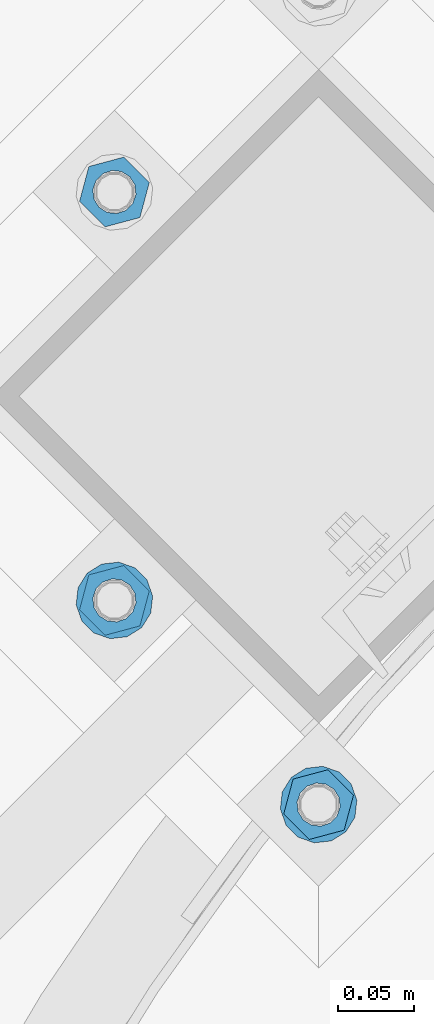
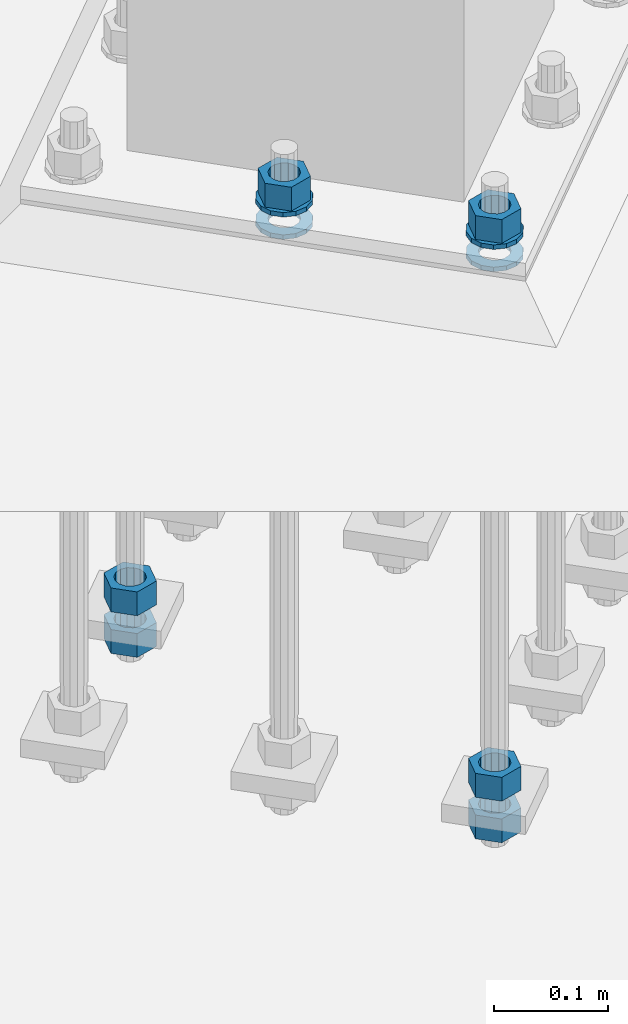
# One storey, part 872 of 1876: 10 columns, 1 element without a shape of its own.
"""IFC2X3 building model written with IfcOpenShell, lengths in millimetres."""

import ifcopenshell
import ifcopenshell.guid

model = None  # the IFC model being written
_history = None  # IfcOwnerHistory: only IFC2X3 demands one
_inside = {}  # id of a spatial element -> (the spatial element, [elements in it])
_under = {}  # id of a project, library or spatial element -> (it, [spatial elements below it])
_declared = {}  # id of a project -> (the project, [libraries it declares])
_typed = {}  # id of a type object -> (the type object, [elements of that type])
_made_of = {}  # id of a material, layer set ... -> (it, [elements and type objects made of it])


def new_model(schema):
    """Start an empty IFC model of exactly this schema.

    Asked for "IFC4X3", IfcOpenShell would pick the latest addendum, in which some entities
    have other attributes; the version numbers below select the first issue.
    IFC2X3 requires an IfcOwnerHistory on every rooted entity: one is made here for all.
    """
    global model, _history
    if schema == "IFC4X3":
        model = ifcopenshell.file(schema_version=(4, 3, 0, 0))
    else:
        model = ifcopenshell.file(schema=schema)
    _inside.clear()
    _under.clear()
    _declared.clear()
    _typed.clear()
    _made_of.clear()
    _history = None
    if model.schema == "IFC2X3":
        org = make("IfcOrganization", Name="unknown")
        user = make(
            "IfcPersonAndOrganization",
            ThePerson=make("IfcPerson", FamilyName="unknown"),
            TheOrganization=org,
        )
        app = make(
            "IfcApplication",
            ApplicationDeveloper=org,
            Version="unknown",
            ApplicationFullName="unknown",
            ApplicationIdentifier="unknown",
        )
        _history = make(
            "IfcOwnerHistory",
            OwningUser=user,
            OwningApplication=app,
            ChangeAction="ADDED",
            CreationDate=0,
        )
    return model


def make(cls, **values):
    """One entity of the class cls with the attributes given. An attribute that is None is left unset."""
    return model.create_entity(
        cls, **{name: value for name, value in values.items() if value is not None}
    )


def rooted(cls, **values):
    """An entity with a GlobalId (a new one), such as an element, a storey or a relation."""
    return make(cls, GlobalId=ifcopenshell.guid.new(), OwnerHistory=_history, **values)


def si_unit(unit_type, name, prefix=None):
    """IfcSIUnit, for example si_unit("LENGTHUNIT", "METRE", prefix="MILLI")."""
    return make("IfcSIUnit", UnitType=unit_type, Prefix=prefix, Name=name)


def assignment(units):
    """IfcUnitAssignment: the units of a project."""
    return None if units is None else make("IfcUnitAssignment", Units=units)


def point(xyz):
    """IfcCartesianPoint."""
    return None if xyz is None else make("IfcCartesianPoint", Coordinates=xyz)


def direction(xyz):
    """IfcDirection."""
    return None if xyz is None else make("IfcDirection", DirectionRatios=xyz)


def frame(location, z_axis=None, x_axis=None):
    """IfcAxis2Placement3D, a coordinate frame: its origin and axes. An axis left out is left unset."""
    return make(
        "IfcAxis2Placement3D",
        Location=point(location),
        Axis=direction(z_axis),
        RefDirection=direction(x_axis),
    )


def origin_with_axes():
    """The frame at (0, 0, 0) with the z axis (0, 0, 1) and the x axis (1, 0, 0) written out."""
    return frame((0.0, 0.0, 0.0), z_axis=(0.0, 0.0, 1.0), x_axis=(1.0, 0.0, 0.0))


def place(relative_to, where):
    """IfcLocalPlacement: puts the frame where relative to a parent placement (None: the world)."""
    return make(
        "IfcLocalPlacement", PlacementRelTo=relative_to, RelativePlacement=where
    )


def context(
    kind, dimensions, precision=None, world=None, true_north=None, identifier=None
):
    """IfcGeometricRepresentationContext, for example the 3D "Model" context."""
    return make(
        "IfcGeometricRepresentationContext",
        ContextIdentifier=identifier,
        ContextType=kind,
        CoordinateSpaceDimension=dimensions,
        Precision=precision,
        WorldCoordinateSystem=world,
        TrueNorth=true_north,
    )


def subcontext(parent, identifier, kind, view, scale=None):
    """IfcGeometricRepresentationSubContext, for example "Body" below "Model"."""
    return make(
        "IfcGeometricRepresentationSubContext",
        ContextIdentifier=identifier,
        ContextType=kind,
        ParentContext=parent,
        TargetScale=scale,
        TargetView=view,
    )


def project(units=None, contexts=None):
    """IfcProject with its units and contexts."""
    return rooted(
        "IfcProject",
        Name="project",
        RepresentationContexts=contexts,
        UnitsInContext=assignment(units),
    )


def spatial(cls, under=None, at=None, **own):
    """A site, building, storey or space (cls), placed at a placement, below another one or the project."""
    s = rooted(cls, ObjectPlacement=at, **own)
    if under is not None:
        _under.setdefault(under.id(), (under, []))[1].append(s)
    return s


def faces_of(points, faces, orient=None, outer=None):
    """IfcFace entities. A face is a list of loops; a loop is a list of indices into points, from 0.

    orient and outer hold one flag for each loop. By default every Orientation is true, the
    first loop of a face is its IfcFaceOuterBound and the others are IfcFaceBound.
    """
    made = []
    for i, loops in enumerate(faces):
        bounds = []
        for j, loop in enumerate(loops):
            is_outer = j == 0 if outer is None else outer[i][j]
            bounds.append(
                make(
                    "IfcFaceOuterBound" if is_outer else "IfcFaceBound",
                    Bound=make("IfcPolyLoop", Polygon=[points[k] for k in loop]),
                    Orientation=True if orient is None else orient[i][j],
                )
            )
        made.append(make("IfcFace", Bounds=bounds))
    return made


def faceted_brep(points, faces, orient=None, outer=None, voids=None):
    """IfcFacetedBrep: a solid bounded by flat faces; with voids (closed shells), ...WithVoids."""
    shared = [point(p) for p in points]
    hull = make("IfcClosedShell", CfsFaces=faces_of(shared, faces, orient, outer))
    if voids is None:
        return make("IfcFacetedBrep", Outer=hull)
    return make(
        "IfcFacetedBrepWithVoids",
        Outer=hull,
        Voids=[
            make(cls, CfsFaces=faces_of(shared, fs, o, b)) for cls, fs, o, b in voids
        ],
    )


def shape(context_of_items, identifier, shape_type, items):
    """IfcShapeRepresentation: the items that make up one representation, for example the "Body"."""
    return make(
        "IfcShapeRepresentation",
        ContextOfItems=context_of_items,
        RepresentationIdentifier=identifier,
        RepresentationType=shape_type,
        Items=items,
    )


def material(Name=None, Category=None):
    """IfcMaterial."""
    return make("IfcMaterial", Name=Name, Category=Category)


def made_of(thing, what):
    """Note that an element or type object is made of a material, layer set ...; save() writes the relation."""
    if what is not None:
        _made_of.setdefault(what.id(), (what, []))[1].append(thing)
    return thing


def type_object(cls, material=None, **own):
    """A type object (cls), such as IfcWallType, which elements share."""
    return made_of(rooted(cls, **own), material)


def element(
    cls,
    number,
    at=None,
    inside=None,
    cuts=None,
    type_object=None,
    material=None,
    context=None,
    identifier="Body",
    shape_type=None,
    held_by="IfcProductDefinitionShape",
    body=None,
    shapes=None,
    **own,
):
    """One element of the class cls, such as IfcWall. Its Tag is "e" and its number.

    at: its placement. inside: the storey or other place that contains it. cuts: it is an
    opening in that element (IfcRelVoidsElement). A single representation is given by context,
    identifier, shape_type and body (its items); several are given by shapes. held_by: the class
    of the entity that holds the representations. save() writes the other relations.
    """
    e = rooted(cls, Tag="e%d" % number, ObjectPlacement=at, **own)
    if body is not None:
        shapes = [shape(context, identifier, shape_type, body)]
    if shapes is not None:
        e.Representation = make(held_by, Representations=shapes)
    if inside is not None:
        _inside.setdefault(inside.id(), (inside, []))[1].append(e)
    if cuts is not None:
        rooted(
            "IfcRelVoidsElement", RelatingBuildingElement=cuts, RelatedOpeningElement=e
        )
    if type_object is not None:
        _typed.setdefault(type_object.id(), (type_object, []))[1].append(e)
    return made_of(e, material)


def aggregate(whole, parts):
    """IfcRelAggregates: a whole, such as a stair, and the parts it consists of."""
    return rooted("IfcRelAggregates", RelatingObject=whole, RelatedObjects=parts)


def save(model, path):
    """Write the relations noted so far, then the file.

    IfcRelAggregates (storeys below a building ...), IfcRelContainedInSpatialStructure (elements
    in a storey), IfcRelDefinesByType, IfcRelAssociatesMaterial and IfcRelDeclares: one each for
    every whole, place, type object, material and project.
    """
    for whole, parts in _under.values():
        aggregate(whole, parts)
    for where, things in _inside.values():
        rooted(
            "IfcRelContainedInSpatialStructure",
            RelatedElements=things,
            RelatingStructure=where,
        )
    for kind, things in _typed.values():
        rooted("IfcRelDefinesByType", RelatedObjects=things, RelatingType=kind)
    for what, things in _made_of.values():
        rooted("IfcRelAssociatesMaterial", RelatedObjects=things, RelatingMaterial=what)
    for by, libraries in _declared.values():
        rooted("IfcRelDeclares", RelatingContext=by, RelatedDefinitions=libraries)
    model.write(path)


model = new_model("IFC2X3")

# Units and contexts
model_context = context("Model", 3, precision=1e-05, world=origin_with_axes())
body_context = subcontext(model_context, "Body", "Model", "MODEL_VIEW")
ifc_project = project(units=[si_unit("LENGTHUNIT", "METRE", prefix="MILLI"), si_unit("AREAUNIT", "SQUARE_METRE"), si_unit("VOLUMEUNIT", "CUBIC_METRE"), si_unit("MASSUNIT", "GRAM", prefix="KILO"), si_unit("TIMEUNIT", "SECOND"), si_unit("PLANEANGLEUNIT", "RADIAN"), si_unit("SOLIDANGLEUNIT", "STERADIAN"), si_unit("THERMODYNAMICTEMPERATUREUNIT", "DEGREE_CELSIUS"), si_unit("LUMINOUSINTENSITYUNIT", "LUMEN")], contexts=[model_context])

# Site, building, storey
site_placement = place(None, origin_with_axes())
site = spatial("IfcSite", under=ifc_project, at=site_placement, CompositionType="ELEMENT")
building_placement = place(site_placement, origin_with_axes())
building = spatial("IfcBuilding", under=site, at=building_placement, Name="Undefined", CompositionType="ELEMENT")
storey_placement = place(building_placement, origin_with_axes())
storey = spatial("IfcBuildingStorey", under=building, at=storey_placement, Name="Undefined", CompositionType="ELEMENT", Elevation=0.0)

# Assembly, columns
assembly_placement = place(storey_placement, origin_with_axes())
assembly = element("IfcElementAssembly", 1, at=assembly_placement, inside=storey, Name="TEMPLATE", AssemblyPlace="NOTDEFINED", PredefinedType="RIGID_FRAME")
ifc_material_1 = material(Name="STEEL/A563")
column_type_1 = type_object("IfcColumnType", Name="1_HEAVY_HEX_NUT", PredefinedType="NOTDEFINED")
column_1_placement = place(assembly_placement, frame((3648.30903754913, -12055.5665371028, -508.0), z_axis=(-0.707106781186547, -0.707106781186548, 0.0), x_axis=(0.0, 0.0, -1.0)))
column_1 = element("IfcColumn", 2, at=column_1_placement, type_object=column_type_1, material=ifc_material_1, Name="NUT", ObjectType="1_HEAVY_HEX_NUT", context=body_context, shape_type="Brep", body=[
    faceted_brep([(0.0, -23.8099994659442, 9.09494701772928e-13), (0.0, -11.9099998474121, -20.6200008392352), (25.4, -11.9099998474157, -20.6200008392361), (25.4, -23.8099994659478, 0.0), (0.0, 11.9099998474157, -20.620000839237), (25.4, 11.9099998474121, -20.620000839237), (0.0, 23.8099994659478, 9.09494701772928e-13), (25.4, 23.8099994659442, 0.0), (0.0, 11.9099998474157, 20.620000839237), (25.4, 11.9099998474121, 20.620000839237), (0.0, -11.9099998474121, 20.6200008392389), (25.4, -11.9099998474157, 20.6200008392379), (0.0, 1.81898940354586e-12, 14.2899999618567), (0.0, 6.20019861543915, 12.8748450879584), (25.4, 6.20019861543733, 12.8748450879593), (25.4, 0.0, 14.2899999618558), (0.0, 11.1723718546473, 8.90966924477925), (25.4, 11.1723718546436, 8.90966924477925), (0.0, 13.9317198278914, 3.17982413774916), (25.4, 13.9317198278877, 3.17982413775007), (0.0, 13.9317198278914, -3.17982413774644), (25.4, 13.9317198278895, -3.17982413774735), (0.0, 11.1723718546473, -8.90966924477834), (25.4, 11.1723718546455, -8.90966924477925), (0.0, 6.20019861544279, -12.8748450879575), (25.4, 6.20019861543915, -12.8748450879584), (0.0, 3.63797880709171e-12, -14.2899999618548), (25.4, -3.63797880709171e-12, -14.2899999618548), (0.0, -6.20019861543733, -12.8748450879566), (25.4, -6.20019861544097, -12.8748450879584), (0.0, -11.1723718546455, -8.90966924477743), (25.4, -11.1723718546473, -8.90966924477834), (0.0, -13.9317198278877, -3.17982413774735), (25.4, -13.9317198278914, -3.17982413774826), (0.0, -13.9317198278895, 3.17982413774735), (25.4, -13.9317198278914, 3.17982413774826), (0.0, -11.1723718546455, 8.90966924477925), (25.4, -11.1723718546473, 8.90966924478016), (0.0, -6.20019861543915, 12.8748450879593), (25.4, -6.20019861544279, 12.8748450879593)], [[[0, 1, 2, 3]], [[1, 4, 5, 2]], [[4, 6, 7, 5]], [[6, 8, 9, 7]], [[8, 10, 11, 9]], [[10, 0, 3, 11]], [[12, 13, 14, 15]], [[13, 16, 17, 14]], [[16, 18, 19, 17]], [[18, 20, 21, 19]], [[20, 22, 23, 21]], [[22, 24, 25, 23]], [[24, 26, 27, 25]], [[26, 28, 29, 27]], [[28, 30, 31, 29]], [[30, 32, 33, 31]], [[32, 34, 35, 33]], [[34, 36, 37, 35]], [[36, 38, 39, 37]], [[38, 12, 15, 39]], [[5, 7, 9, 11, 3, 2], [17, 19, 21, 23, 25, 27, 29, 31, 33, 35, 37, 39, 15, 14]], [[10, 8, 6, 4, 1, 0], [38, 36, 34, 32, 30, 28, 26, 24, 22, 20, 18, 16, 13, 12]]]),
])
column_2_placement = place(assembly_placement, frame((3648.30903754913, -12055.5665371028, -552.45), z_axis=(-0.707106781186547, -0.707106781186548, 0.0), x_axis=(0.0, 0.0, -1.0)))
column_2 = element("IfcColumn", 3, at=column_2_placement, type_object=column_type_1, material=ifc_material_1, Name="NUT", ObjectType="1_HEAVY_HEX_NUT", context=body_context, shape_type="Brep", body=[
    faceted_brep([(0.0, -23.8099994659442, 9.09494701772928e-13), (0.0, -11.9099998474121, -20.6200008392352), (25.4, -11.9099998474157, -20.6200008392361), (25.4, -23.8099994659478, 0.0), (0.0, 11.9099998474157, -20.620000839237), (25.4, 11.9099998474121, -20.620000839237), (0.0, 23.8099994659478, 9.09494701772928e-13), (25.4, 23.8099994659442, 0.0), (0.0, 11.9099998474157, 20.620000839237), (25.4, 11.9099998474121, 20.620000839237), (0.0, -11.9099998474121, 20.6200008392389), (25.4, -11.9099998474157, 20.6200008392379), (0.0, 1.81898940354586e-12, 14.2899999618567), (0.0, 6.20019861543915, 12.8748450879584), (25.4, 6.20019861543733, 12.8748450879593), (25.4, 0.0, 14.2899999618558), (0.0, 11.1723718546473, 8.90966924477925), (25.4, 11.1723718546436, 8.90966924477925), (0.0, 13.9317198278914, 3.17982413774916), (25.4, 13.9317198278877, 3.17982413775007), (0.0, 13.9317198278914, -3.17982413774644), (25.4, 13.9317198278895, -3.17982413774735), (0.0, 11.1723718546473, -8.90966924477834), (25.4, 11.1723718546455, -8.90966924477925), (0.0, 6.20019861544279, -12.8748450879575), (25.4, 6.20019861543915, -12.8748450879584), (0.0, 3.63797880709171e-12, -14.2899999618548), (25.4, -3.63797880709171e-12, -14.2899999618548), (0.0, -6.20019861543733, -12.8748450879566), (25.4, -6.20019861544097, -12.8748450879584), (0.0, -11.1723718546455, -8.90966924477743), (25.4, -11.1723718546473, -8.90966924477834), (0.0, -13.9317198278877, -3.17982413774735), (25.4, -13.9317198278914, -3.17982413774826), (0.0, -13.9317198278895, 3.17982413774735), (25.4, -13.9317198278914, 3.17982413774826), (0.0, -11.1723718546455, 8.90966924477925), (25.4, -11.1723718546473, 8.90966924478016), (0.0, -6.20019861543915, 12.8748450879593), (25.4, -6.20019861544279, 12.8748450879593)], [[[0, 1, 2, 3]], [[1, 4, 5, 2]], [[4, 6, 7, 5]], [[6, 8, 9, 7]], [[8, 10, 11, 9]], [[10, 0, 3, 11]], [[12, 13, 14, 15]], [[13, 16, 17, 14]], [[16, 18, 19, 17]], [[18, 20, 21, 19]], [[20, 22, 23, 21]], [[22, 24, 25, 23]], [[24, 26, 27, 25]], [[26, 28, 29, 27]], [[28, 30, 31, 29]], [[30, 32, 33, 31]], [[32, 34, 35, 33]], [[34, 36, 37, 35]], [[36, 38, 39, 37]], [[38, 12, 15, 39]], [[5, 7, 9, 11, 3, 2], [17, 19, 21, 23, 25, 27, 29, 31, 33, 35, 37, 39, 15, 14]], [[10, 8, 6, 4, 1, 0], [38, 36, 34, 32, 30, 28, 26, 24, 22, 20, 18, 16, 13, 12]]]),
])
column_3_placement = place(assembly_placement, frame((3783.01287936528, -12459.6780625513, 87.3125), z_axis=(0.707106781186548, 0.707106781186547, 0.0), x_axis=(0.0, 0.0, -1.0)))
column_3 = element("IfcColumn", 4, at=column_3_placement, type_object=column_type_1, material=ifc_material_1, Name="NUT", ObjectType="1_HEAVY_HEX_NUT", context=body_context, shape_type="Brep", body=[
    faceted_brep([(0.0, -23.8099994659442, 9.09494701772928e-13), (0.0, -11.9099998474121, -20.6200008392352), (25.4, -11.9099998474157, -20.6200008392361), (25.4, -23.8099994659478, 0.0), (0.0, 11.9099998474157, -20.620000839237), (25.4, 11.9099998474121, -20.620000839237), (0.0, 23.8099994659478, 9.09494701772928e-13), (25.4, 23.8099994659442, 0.0), (0.0, 11.9099998474157, 20.620000839237), (25.4, 11.9099998474121, 20.620000839237), (0.0, -11.9099998474121, 20.6200008392389), (25.4, -11.9099998474157, 20.6200008392379), (0.0, 1.81898940354586e-12, 14.2899999618567), (0.0, 6.20019861543915, 12.8748450879584), (25.4, 6.20019861543733, 12.8748450879593), (25.4, 0.0, 14.2899999618558), (0.0, 11.1723718546473, 8.90966924477925), (25.4, 11.1723718546436, 8.90966924477925), (0.0, 13.9317198278914, 3.17982413774916), (25.4, 13.9317198278877, 3.17982413775007), (0.0, 13.9317198278914, -3.17982413774644), (25.4, 13.9317198278895, -3.17982413774735), (0.0, 11.1723718546473, -8.90966924477834), (25.4, 11.1723718546455, -8.90966924477925), (0.0, 6.20019861544279, -12.8748450879575), (25.4, 6.20019861543915, -12.8748450879584), (0.0, 3.63797880709171e-12, -14.2899999618548), (25.4, -3.63797880709171e-12, -14.2899999618548), (0.0, -6.20019861543733, -12.8748450879566), (25.4, -6.20019861544097, -12.8748450879584), (0.0, -11.1723718546455, -8.90966924477743), (25.4, -11.1723718546473, -8.90966924477834), (0.0, -13.9317198278877, -3.17982413774735), (25.4, -13.9317198278914, -3.17982413774826), (0.0, -13.9317198278895, 3.17982413774735), (25.4, -13.9317198278914, 3.17982413774826), (0.0, -11.1723718546455, 8.90966924477925), (25.4, -11.1723718546473, 8.90966924478016), (0.0, -6.20019861543915, 12.8748450879593), (25.4, -6.20019861544279, 12.8748450879593)], [[[0, 1, 2, 3]], [[1, 4, 5, 2]], [[4, 6, 7, 5]], [[6, 8, 9, 7]], [[8, 10, 11, 9]], [[10, 0, 3, 11]], [[12, 13, 14, 15]], [[13, 16, 17, 14]], [[16, 18, 19, 17]], [[18, 20, 21, 19]], [[20, 22, 23, 21]], [[22, 24, 25, 23]], [[24, 26, 27, 25]], [[26, 28, 29, 27]], [[28, 30, 31, 29]], [[30, 32, 33, 31]], [[32, 34, 35, 33]], [[34, 36, 37, 35]], [[36, 38, 39, 37]], [[38, 12, 15, 39]], [[5, 7, 9, 11, 3, 2], [17, 19, 21, 23, 25, 27, 29, 31, 33, 35, 37, 39, 15, 14]], [[10, 8, 6, 4, 1, 0], [38, 36, 34, 32, 30, 28, 26, 24, 22, 20, 18, 16, 13, 12]]]),
])
column_4_placement = place(assembly_placement, frame((3783.01287936528, -12459.6780625513, -508.0), z_axis=(0.707106781186548, 0.707106781186547, 0.0), x_axis=(0.0, 0.0, -1.0)))
column_4 = element("IfcColumn", 5, at=column_4_placement, type_object=column_type_1, material=ifc_material_1, Name="NUT", ObjectType="1_HEAVY_HEX_NUT", context=body_context, shape_type="Brep", body=[
    faceted_brep([(0.0, -23.8099994659442, 9.09494701772928e-13), (0.0, -11.9099998474121, -20.6200008392352), (25.4, -11.9099998474157, -20.6200008392361), (25.4, -23.8099994659478, 0.0), (0.0, 11.9099998474157, -20.620000839237), (25.4, 11.9099998474121, -20.620000839237), (0.0, 23.8099994659478, 9.09494701772928e-13), (25.4, 23.8099994659442, 0.0), (0.0, 11.9099998474157, 20.620000839237), (25.4, 11.9099998474121, 20.620000839237), (0.0, -11.9099998474121, 20.6200008392389), (25.4, -11.9099998474157, 20.6200008392379), (0.0, 1.81898940354586e-12, 14.2899999618567), (0.0, 6.20019861543915, 12.8748450879584), (25.4, 6.20019861543733, 12.8748450879593), (25.4, 0.0, 14.2899999618558), (0.0, 11.1723718546473, 8.90966924477925), (25.4, 11.1723718546436, 8.90966924477925), (0.0, 13.9317198278914, 3.17982413774916), (25.4, 13.9317198278877, 3.17982413775007), (0.0, 13.9317198278914, -3.17982413774644), (25.4, 13.9317198278895, -3.17982413774735), (0.0, 11.1723718546473, -8.90966924477834), (25.4, 11.1723718546455, -8.90966924477925), (0.0, 6.20019861544279, -12.8748450879575), (25.4, 6.20019861543915, -12.8748450879584), (0.0, 3.63797880709171e-12, -14.2899999618548), (25.4, -3.63797880709171e-12, -14.2899999618548), (0.0, -6.20019861543733, -12.8748450879566), (25.4, -6.20019861544097, -12.8748450879584), (0.0, -11.1723718546455, -8.90966924477743), (25.4, -11.1723718546473, -8.90966924477834), (0.0, -13.9317198278877, -3.17982413774735), (25.4, -13.9317198278914, -3.17982413774826), (0.0, -13.9317198278895, 3.17982413774735), (25.4, -13.9317198278914, 3.17982413774826), (0.0, -11.1723718546455, 8.90966924477925), (25.4, -11.1723718546473, 8.90966924478016), (0.0, -6.20019861543915, 12.8748450879593), (25.4, -6.20019861544279, 12.8748450879593)], [[[0, 1, 2, 3]], [[1, 4, 5, 2]], [[4, 6, 7, 5]], [[6, 8, 9, 7]], [[8, 10, 11, 9]], [[10, 0, 3, 11]], [[12, 13, 14, 15]], [[13, 16, 17, 14]], [[16, 18, 19, 17]], [[18, 20, 21, 19]], [[20, 22, 23, 21]], [[22, 24, 25, 23]], [[24, 26, 27, 25]], [[26, 28, 29, 27]], [[28, 30, 31, 29]], [[30, 32, 33, 31]], [[32, 34, 35, 33]], [[34, 36, 37, 35]], [[36, 38, 39, 37]], [[38, 12, 15, 39]], [[5, 7, 9, 11, 3, 2], [17, 19, 21, 23, 25, 27, 29, 31, 33, 35, 37, 39, 15, 14]], [[10, 8, 6, 4, 1, 0], [38, 36, 34, 32, 30, 28, 26, 24, 22, 20, 18, 16, 13, 12]]]),
])
column_5_placement = place(assembly_placement, frame((3783.01287936528, -12459.6780625513, -552.45), z_axis=(0.707106781186548, 0.707106781186547, 0.0), x_axis=(0.0, 0.0, -1.0)))
column_5 = element("IfcColumn", 6, at=column_5_placement, type_object=column_type_1, material=ifc_material_1, Name="NUT", ObjectType="1_HEAVY_HEX_NUT", context=body_context, shape_type="Brep", body=[
    faceted_brep([(0.0, -23.8099994659442, 9.09494701772928e-13), (0.0, -11.9099998474121, -20.6200008392352), (25.4, -11.9099998474157, -20.6200008392361), (25.4, -23.8099994659478, 0.0), (0.0, 11.9099998474157, -20.620000839237), (25.4, 11.9099998474121, -20.620000839237), (0.0, 23.8099994659478, 9.09494701772928e-13), (25.4, 23.8099994659442, 0.0), (0.0, 11.9099998474157, 20.620000839237), (25.4, 11.9099998474121, 20.620000839237), (0.0, -11.9099998474121, 20.6200008392389), (25.4, -11.9099998474157, 20.6200008392379), (0.0, 1.81898940354586e-12, 14.2899999618567), (0.0, 6.20019861543915, 12.8748450879584), (25.4, 6.20019861543733, 12.8748450879593), (25.4, 0.0, 14.2899999618558), (0.0, 11.1723718546473, 8.90966924477925), (25.4, 11.1723718546436, 8.90966924477925), (0.0, 13.9317198278914, 3.17982413774916), (25.4, 13.9317198278877, 3.17982413775007), (0.0, 13.9317198278914, -3.17982413774644), (25.4, 13.9317198278895, -3.17982413774735), (0.0, 11.1723718546473, -8.90966924477834), (25.4, 11.1723718546455, -8.90966924477925), (0.0, 6.20019861544279, -12.8748450879575), (25.4, 6.20019861543915, -12.8748450879584), (0.0, 3.63797880709171e-12, -14.2899999618548), (25.4, -3.63797880709171e-12, -14.2899999618548), (0.0, -6.20019861543733, -12.8748450879566), (25.4, -6.20019861544097, -12.8748450879584), (0.0, -11.1723718546455, -8.90966924477743), (25.4, -11.1723718546473, -8.90966924477834), (0.0, -13.9317198278877, -3.17982413774735), (25.4, -13.9317198278914, -3.17982413774826), (0.0, -13.9317198278895, 3.17982413774735), (25.4, -13.9317198278914, 3.17982413774826), (0.0, -11.1723718546455, 8.90966924477925), (25.4, -11.1723718546473, 8.90966924478016), (0.0, -6.20019861543915, 12.8748450879593), (25.4, -6.20019861544279, 12.8748450879593)], [[[0, 1, 2, 3]], [[1, 4, 5, 2]], [[4, 6, 7, 5]], [[6, 8, 9, 7]], [[8, 10, 11, 9]], [[10, 0, 3, 11]], [[12, 13, 14, 15]], [[13, 16, 17, 14]], [[16, 18, 19, 17]], [[18, 20, 21, 19]], [[20, 22, 23, 21]], [[22, 24, 25, 23]], [[24, 26, 27, 25]], [[26, 28, 29, 27]], [[28, 30, 31, 29]], [[30, 32, 33, 31]], [[32, 34, 35, 33]], [[34, 36, 37, 35]], [[36, 38, 39, 37]], [[38, 12, 15, 39]], [[5, 7, 9, 11, 3, 2], [17, 19, 21, 23, 25, 27, 29, 31, 33, 35, 37, 39, 15, 14]], [[10, 8, 6, 4, 1, 0], [38, 36, 34, 32, 30, 28, 26, 24, 22, 20, 18, 16, 13, 12]]]),
])
column_6_placement = place(assembly_placement, frame((3648.30903754913, -12324.9742207351, 87.3125), z_axis=(0.707106781186548, 0.707106781186547, 0.0), x_axis=(0.0, 0.0, -1.0)))
column_6 = element("IfcColumn", 7, at=column_6_placement, type_object=column_type_1, material=ifc_material_1, Name="NUT", ObjectType="1_HEAVY_HEX_NUT", context=body_context, shape_type="Brep", body=[
    faceted_brep([(0.0, -23.8099994659442, 9.09494701772928e-13), (0.0, -11.9099998474121, -20.6200008392352), (25.4, -11.9099998474157, -20.6200008392361), (25.4, -23.8099994659478, 0.0), (0.0, 11.9099998474157, -20.620000839237), (25.4, 11.9099998474121, -20.620000839237), (0.0, 23.8099994659478, 9.09494701772928e-13), (25.4, 23.8099994659442, 0.0), (0.0, 11.9099998474157, 20.620000839237), (25.4, 11.9099998474121, 20.620000839237), (0.0, -11.9099998474121, 20.6200008392389), (25.4, -11.9099998474157, 20.6200008392379), (0.0, 1.81898940354586e-12, 14.2899999618567), (0.0, 6.20019861543915, 12.8748450879584), (25.4, 6.20019861543733, 12.8748450879593), (25.4, 0.0, 14.2899999618558), (0.0, 11.1723718546473, 8.90966924477925), (25.4, 11.1723718546436, 8.90966924477925), (0.0, 13.9317198278914, 3.17982413774916), (25.4, 13.9317198278877, 3.17982413775007), (0.0, 13.9317198278914, -3.17982413774644), (25.4, 13.9317198278895, -3.17982413774735), (0.0, 11.1723718546473, -8.90966924477834), (25.4, 11.1723718546455, -8.90966924477925), (0.0, 6.20019861544279, -12.8748450879575), (25.4, 6.20019861543915, -12.8748450879584), (0.0, 3.63797880709171e-12, -14.2899999618548), (25.4, -3.63797880709171e-12, -14.2899999618548), (0.0, -6.20019861543733, -12.8748450879566), (25.4, -6.20019861544097, -12.8748450879584), (0.0, -11.1723718546455, -8.90966924477743), (25.4, -11.1723718546473, -8.90966924477834), (0.0, -13.9317198278877, -3.17982413774735), (25.4, -13.9317198278914, -3.17982413774826), (0.0, -13.9317198278895, 3.17982413774735), (25.4, -13.9317198278914, 3.17982413774826), (0.0, -11.1723718546455, 8.90966924477925), (25.4, -11.1723718546473, 8.90966924478016), (0.0, -6.20019861543915, 12.8748450879593), (25.4, -6.20019861544279, 12.8748450879593)], [[[0, 1, 2, 3]], [[1, 4, 5, 2]], [[4, 6, 7, 5]], [[6, 8, 9, 7]], [[8, 10, 11, 9]], [[10, 0, 3, 11]], [[12, 13, 14, 15]], [[13, 16, 17, 14]], [[16, 18, 19, 17]], [[18, 20, 21, 19]], [[20, 22, 23, 21]], [[22, 24, 25, 23]], [[24, 26, 27, 25]], [[26, 28, 29, 27]], [[28, 30, 31, 29]], [[30, 32, 33, 31]], [[32, 34, 35, 33]], [[34, 36, 37, 35]], [[36, 38, 39, 37]], [[38, 12, 15, 39]], [[5, 7, 9, 11, 3, 2], [17, 19, 21, 23, 25, 27, 29, 31, 33, 35, 37, 39, 15, 14]], [[10, 8, 6, 4, 1, 0], [38, 36, 34, 32, 30, 28, 26, 24, 22, 20, 18, 16, 13, 12]]]),
])
ifc_material_2 = material(Name="STEEL/F436")
column_type_2 = type_object("IfcColumnType", Name="1_WASHER", PredefinedType="NOTDEFINED")
column_7_placement = place(assembly_placement, frame((3783.01287936528, -12459.6780625513, 38.1), z_axis=(0.707106781186548, 0.707106781186547, 0.0), x_axis=(0.0, 0.0, -1.0)))
column_7 = element("IfcColumn", 8, at=column_7_placement, type_object=column_type_2, material=ifc_material_2, Name="WASHER", ObjectType="1_WASHER", context=body_context, shape_type="Brep", body=[
    faceted_brep([(0.0, -25.3999996185375, 0.0), (0.0, -22.8846089010331, -11.0206468080742), (4.7625, -22.8846089010331, -11.0206468080742), (4.7625, -25.3999996185375, 0.0), (0.0, -15.8366407293743, -19.8585193564477), (4.7625, -15.8366407293743, -19.8585193564477), (0.0, -5.65203163760816, -24.7631685975166), (4.7625, -5.65203163760816, -24.7631685975166), (0.0, 5.65203163760452, -24.7631685975166), (4.7625, 5.65203163760452, -24.7631685975166), (0.0, 15.8366407293706, -19.858519356445), (4.7625, 15.8366407293706, -19.858519356445), (0.0, 22.8846089010331, -11.0206468080733), (4.7625, 22.8846089010331, -11.0206468080733), (0.0, 25.3999996185339, 9.09494701772928e-13), (4.7625, 25.3999996185339, 9.09494701772928e-13), (0.0, 22.8846089010331, 11.0206468080751), (4.7625, 22.8846089010331, 11.0206468080751), (0.0, 15.8366407293706, 19.8585193564486), (4.7625, 15.8366407293706, 19.8585193564486), (0.0, 5.65203163760452, 24.7631685975175), (4.7625, 5.65203163760452, 24.7631685975175), (0.0, -5.65203163760816, 24.7631685975175), (4.7625, -5.65203163760816, 24.7631685975175), (0.0, -15.8366407293724, 19.8585193564459), (4.7625, -15.8366407293724, 19.8585193564459), (0.0, -22.8846089010367, 11.0206468080751), (4.7625, -22.8846089010367, 11.0206468080751), (0.0, 1.81898940354586e-12, 14.2899999618567), (0.0, 6.20019861543915, 12.8748450879584), (4.7625, 6.20019861543733, 12.8748450879593), (4.7625, 0.0, 14.2899999618558), (0.0, 11.1723718546473, 8.90966924477925), (4.7625, 11.1723718546436, 8.90966924477925), (0.0, 13.9317198278914, 3.17982413774916), (4.7625, 13.9317198278877, 3.17982413775007), (0.0, 13.9317198278914, -3.17982413774644), (4.7625, 13.9317198278895, -3.17982413774735), (0.0, 11.1723718546473, -8.90966924477834), (4.7625, 11.1723718546455, -8.90966924477925), (0.0, 6.20019861544279, -12.8748450879575), (4.7625, 6.20019861543915, -12.8748450879584), (0.0, 3.63797880709171e-12, -14.2899999618548), (4.7625, -3.63797880709171e-12, -14.2899999618548), (0.0, -6.20019861543733, -12.8748450879566), (4.7625, -6.20019861544097, -12.8748450879584), (0.0, -11.1723718546455, -8.90966924477743), (4.7625, -11.1723718546473, -8.90966924477834), (0.0, -13.9317198278877, -3.17982413774735), (4.7625, -13.9317198278914, -3.17982413774826), (0.0, -13.9317198278895, 3.17982413774735), (4.7625, -13.9317198278914, 3.17982413774826), (0.0, -11.1723718546455, 8.90966924477925), (4.7625, -11.1723718546473, 8.90966924478016), (0.0, -6.20019861543915, 12.8748450879593), (4.7625, -6.20019861544279, 12.8748450879593)], [[[0, 1, 2, 3]], [[1, 4, 5, 2]], [[4, 6, 7, 5]], [[6, 8, 9, 7]], [[8, 10, 11, 9]], [[10, 12, 13, 11]], [[12, 14, 15, 13]], [[14, 16, 17, 15]], [[16, 18, 19, 17]], [[18, 20, 21, 19]], [[20, 22, 23, 21]], [[22, 24, 25, 23]], [[24, 26, 27, 25]], [[26, 0, 3, 27]], [[28, 29, 30, 31]], [[29, 32, 33, 30]], [[32, 34, 35, 33]], [[34, 36, 37, 35]], [[36, 38, 39, 37]], [[38, 40, 41, 39]], [[40, 42, 43, 41]], [[42, 44, 45, 43]], [[44, 46, 47, 45]], [[46, 48, 49, 47]], [[48, 50, 51, 49]], [[50, 52, 53, 51]], [[52, 54, 55, 53]], [[54, 28, 31, 55]], [[5, 7, 9, 11, 13, 15, 17, 19, 21, 23, 25, 27, 3, 2], [33, 35, 37, 39, 41, 43, 45, 47, 49, 51, 53, 55, 31, 30]], [[26, 24, 22, 20, 18, 16, 14, 12, 10, 8, 6, 4, 1, 0], [54, 52, 50, 48, 46, 44, 42, 40, 38, 36, 34, 32, 29, 28]]]),
])
column_8_placement = place(assembly_placement, frame((3783.01287936528, -12459.6780625513, 61.9125), z_axis=(0.707106781186548, 0.707106781186547, 0.0), x_axis=(0.0, 0.0, -1.0)))
column_8 = element("IfcColumn", 9, at=column_8_placement, type_object=column_type_2, material=ifc_material_2, Name="WASHER", ObjectType="1_WASHER", context=body_context, shape_type="Brep", body=[
    faceted_brep([(0.0, -25.3999996185375, 0.0), (0.0, -22.8846089010331, -11.0206468080742), (4.7625, -22.8846089010331, -11.0206468080742), (4.7625, -25.3999996185375, 0.0), (0.0, -15.8366407293743, -19.8585193564477), (4.7625, -15.8366407293743, -19.8585193564477), (0.0, -5.65203163760816, -24.7631685975166), (4.7625, -5.65203163760816, -24.7631685975166), (0.0, 5.65203163760452, -24.7631685975166), (4.7625, 5.65203163760452, -24.7631685975166), (0.0, 15.8366407293706, -19.858519356445), (4.7625, 15.8366407293706, -19.858519356445), (0.0, 22.8846089010331, -11.0206468080733), (4.7625, 22.8846089010331, -11.0206468080733), (0.0, 25.3999996185339, 9.09494701772928e-13), (4.7625, 25.3999996185339, 9.09494701772928e-13), (0.0, 22.8846089010331, 11.0206468080751), (4.7625, 22.8846089010331, 11.0206468080751), (0.0, 15.8366407293706, 19.8585193564486), (4.7625, 15.8366407293706, 19.8585193564486), (0.0, 5.65203163760452, 24.7631685975175), (4.7625, 5.65203163760452, 24.7631685975175), (0.0, -5.65203163760816, 24.7631685975175), (4.7625, -5.65203163760816, 24.7631685975175), (0.0, -15.8366407293724, 19.8585193564459), (4.7625, -15.8366407293724, 19.8585193564459), (0.0, -22.8846089010367, 11.0206468080751), (4.7625, -22.8846089010367, 11.0206468080751), (0.0, 1.81898940354586e-12, 14.2899999618567), (0.0, 6.20019861543915, 12.8748450879584), (4.7625, 6.20019861543733, 12.8748450879593), (4.7625, 0.0, 14.2899999618558), (0.0, 11.1723718546473, 8.90966924477925), (4.7625, 11.1723718546436, 8.90966924477925), (0.0, 13.9317198278914, 3.17982413774916), (4.7625, 13.9317198278877, 3.17982413775007), (0.0, 13.9317198278914, -3.17982413774644), (4.7625, 13.9317198278895, -3.17982413774735), (0.0, 11.1723718546473, -8.90966924477834), (4.7625, 11.1723718546455, -8.90966924477925), (0.0, 6.20019861544279, -12.8748450879575), (4.7625, 6.20019861543915, -12.8748450879584), (0.0, 3.63797880709171e-12, -14.2899999618548), (4.7625, -3.63797880709171e-12, -14.2899999618548), (0.0, -6.20019861543733, -12.8748450879566), (4.7625, -6.20019861544097, -12.8748450879584), (0.0, -11.1723718546455, -8.90966924477743), (4.7625, -11.1723718546473, -8.90966924477834), (0.0, -13.9317198278877, -3.17982413774735), (4.7625, -13.9317198278914, -3.17982413774826), (0.0, -13.9317198278895, 3.17982413774735), (4.7625, -13.9317198278914, 3.17982413774826), (0.0, -11.1723718546455, 8.90966924477925), (4.7625, -11.1723718546473, 8.90966924478016), (0.0, -6.20019861543915, 12.8748450879593), (4.7625, -6.20019861544279, 12.8748450879593)], [[[0, 1, 2, 3]], [[1, 4, 5, 2]], [[4, 6, 7, 5]], [[6, 8, 9, 7]], [[8, 10, 11, 9]], [[10, 12, 13, 11]], [[12, 14, 15, 13]], [[14, 16, 17, 15]], [[16, 18, 19, 17]], [[18, 20, 21, 19]], [[20, 22, 23, 21]], [[22, 24, 25, 23]], [[24, 26, 27, 25]], [[26, 0, 3, 27]], [[28, 29, 30, 31]], [[29, 32, 33, 30]], [[32, 34, 35, 33]], [[34, 36, 37, 35]], [[36, 38, 39, 37]], [[38, 40, 41, 39]], [[40, 42, 43, 41]], [[42, 44, 45, 43]], [[44, 46, 47, 45]], [[46, 48, 49, 47]], [[48, 50, 51, 49]], [[50, 52, 53, 51]], [[52, 54, 55, 53]], [[54, 28, 31, 55]], [[5, 7, 9, 11, 13, 15, 17, 19, 21, 23, 25, 27, 3, 2], [33, 35, 37, 39, 41, 43, 45, 47, 49, 51, 53, 55, 31, 30]], [[26, 24, 22, 20, 18, 16, 14, 12, 10, 8, 6, 4, 1, 0], [54, 52, 50, 48, 46, 44, 42, 40, 38, 36, 34, 32, 29, 28]]]),
])
column_9_placement = place(assembly_placement, frame((3648.30903754913, -12324.9742207351, 38.1), z_axis=(0.707106781186548, 0.707106781186547, 0.0), x_axis=(0.0, 0.0, -1.0)))
column_9 = element("IfcColumn", 10, at=column_9_placement, type_object=column_type_2, material=ifc_material_2, Name="WASHER", ObjectType="1_WASHER", context=body_context, shape_type="Brep", body=[
    faceted_brep([(0.0, -25.3999996185375, 0.0), (0.0, -22.8846089010331, -11.0206468080742), (4.7625, -22.8846089010331, -11.0206468080742), (4.7625, -25.3999996185375, 0.0), (0.0, -15.8366407293743, -19.8585193564477), (4.7625, -15.8366407293743, -19.8585193564477), (0.0, -5.65203163760816, -24.7631685975166), (4.7625, -5.65203163760816, -24.7631685975166), (0.0, 5.65203163760452, -24.7631685975166), (4.7625, 5.65203163760452, -24.7631685975166), (0.0, 15.8366407293706, -19.858519356445), (4.7625, 15.8366407293706, -19.858519356445), (0.0, 22.8846089010331, -11.0206468080733), (4.7625, 22.8846089010331, -11.0206468080733), (0.0, 25.3999996185339, 9.09494701772928e-13), (4.7625, 25.3999996185339, 9.09494701772928e-13), (0.0, 22.8846089010331, 11.0206468080751), (4.7625, 22.8846089010331, 11.0206468080751), (0.0, 15.8366407293706, 19.8585193564486), (4.7625, 15.8366407293706, 19.8585193564486), (0.0, 5.65203163760452, 24.7631685975175), (4.7625, 5.65203163760452, 24.7631685975175), (0.0, -5.65203163760816, 24.7631685975175), (4.7625, -5.65203163760816, 24.7631685975175), (0.0, -15.8366407293724, 19.8585193564459), (4.7625, -15.8366407293724, 19.8585193564459), (0.0, -22.8846089010367, 11.0206468080751), (4.7625, -22.8846089010367, 11.0206468080751), (0.0, 1.81898940354586e-12, 14.2899999618567), (0.0, 6.20019861543915, 12.8748450879584), (4.7625, 6.20019861543733, 12.8748450879593), (4.7625, 0.0, 14.2899999618558), (0.0, 11.1723718546473, 8.90966924477925), (4.7625, 11.1723718546436, 8.90966924477925), (0.0, 13.9317198278914, 3.17982413774916), (4.7625, 13.9317198278877, 3.17982413775007), (0.0, 13.9317198278914, -3.17982413774644), (4.7625, 13.9317198278895, -3.17982413774735), (0.0, 11.1723718546473, -8.90966924477834), (4.7625, 11.1723718546455, -8.90966924477925), (0.0, 6.20019861544279, -12.8748450879575), (4.7625, 6.20019861543915, -12.8748450879584), (0.0, 3.63797880709171e-12, -14.2899999618548), (4.7625, -3.63797880709171e-12, -14.2899999618548), (0.0, -6.20019861543733, -12.8748450879566), (4.7625, -6.20019861544097, -12.8748450879584), (0.0, -11.1723718546455, -8.90966924477743), (4.7625, -11.1723718546473, -8.90966924477834), (0.0, -13.9317198278877, -3.17982413774735), (4.7625, -13.9317198278914, -3.17982413774826), (0.0, -13.9317198278895, 3.17982413774735), (4.7625, -13.9317198278914, 3.17982413774826), (0.0, -11.1723718546455, 8.90966924477925), (4.7625, -11.1723718546473, 8.90966924478016), (0.0, -6.20019861543915, 12.8748450879593), (4.7625, -6.20019861544279, 12.8748450879593)], [[[0, 1, 2, 3]], [[1, 4, 5, 2]], [[4, 6, 7, 5]], [[6, 8, 9, 7]], [[8, 10, 11, 9]], [[10, 12, 13, 11]], [[12, 14, 15, 13]], [[14, 16, 17, 15]], [[16, 18, 19, 17]], [[18, 20, 21, 19]], [[20, 22, 23, 21]], [[22, 24, 25, 23]], [[24, 26, 27, 25]], [[26, 0, 3, 27]], [[28, 29, 30, 31]], [[29, 32, 33, 30]], [[32, 34, 35, 33]], [[34, 36, 37, 35]], [[36, 38, 39, 37]], [[38, 40, 41, 39]], [[40, 42, 43, 41]], [[42, 44, 45, 43]], [[44, 46, 47, 45]], [[46, 48, 49, 47]], [[48, 50, 51, 49]], [[50, 52, 53, 51]], [[52, 54, 55, 53]], [[54, 28, 31, 55]], [[5, 7, 9, 11, 13, 15, 17, 19, 21, 23, 25, 27, 3, 2], [33, 35, 37, 39, 41, 43, 45, 47, 49, 51, 53, 55, 31, 30]], [[26, 24, 22, 20, 18, 16, 14, 12, 10, 8, 6, 4, 1, 0], [54, 52, 50, 48, 46, 44, 42, 40, 38, 36, 34, 32, 29, 28]]]),
])
column_10_placement = place(assembly_placement, frame((3648.30903754913, -12324.9742207351, 61.9125), z_axis=(0.707106781186548, 0.707106781186547, 0.0), x_axis=(0.0, 0.0, -1.0)))
column_10 = element("IfcColumn", 11, at=column_10_placement, type_object=column_type_2, material=ifc_material_2, Name="WASHER", ObjectType="1_WASHER", context=body_context, shape_type="Brep", body=[
    faceted_brep([(0.0, -25.3999996185375, 0.0), (0.0, -22.8846089010331, -11.0206468080742), (4.7625, -22.8846089010331, -11.0206468080742), (4.7625, -25.3999996185375, 0.0), (0.0, -15.8366407293743, -19.8585193564477), (4.7625, -15.8366407293743, -19.8585193564477), (0.0, -5.65203163760816, -24.7631685975166), (4.7625, -5.65203163760816, -24.7631685975166), (0.0, 5.65203163760452, -24.7631685975166), (4.7625, 5.65203163760452, -24.7631685975166), (0.0, 15.8366407293706, -19.858519356445), (4.7625, 15.8366407293706, -19.858519356445), (0.0, 22.8846089010331, -11.0206468080733), (4.7625, 22.8846089010331, -11.0206468080733), (0.0, 25.3999996185339, 9.09494701772928e-13), (4.7625, 25.3999996185339, 9.09494701772928e-13), (0.0, 22.8846089010331, 11.0206468080751), (4.7625, 22.8846089010331, 11.0206468080751), (0.0, 15.8366407293706, 19.8585193564486), (4.7625, 15.8366407293706, 19.8585193564486), (0.0, 5.65203163760452, 24.7631685975175), (4.7625, 5.65203163760452, 24.7631685975175), (0.0, -5.65203163760816, 24.7631685975175), (4.7625, -5.65203163760816, 24.7631685975175), (0.0, -15.8366407293724, 19.8585193564459), (4.7625, -15.8366407293724, 19.8585193564459), (0.0, -22.8846089010367, 11.0206468080751), (4.7625, -22.8846089010367, 11.0206468080751), (0.0, 1.81898940354586e-12, 14.2899999618567), (0.0, 6.20019861543915, 12.8748450879584), (4.7625, 6.20019861543733, 12.8748450879593), (4.7625, 0.0, 14.2899999618558), (0.0, 11.1723718546473, 8.90966924477925), (4.7625, 11.1723718546436, 8.90966924477925), (0.0, 13.9317198278914, 3.17982413774916), (4.7625, 13.9317198278877, 3.17982413775007), (0.0, 13.9317198278914, -3.17982413774644), (4.7625, 13.9317198278895, -3.17982413774735), (0.0, 11.1723718546473, -8.90966924477834), (4.7625, 11.1723718546455, -8.90966924477925), (0.0, 6.20019861544279, -12.8748450879575), (4.7625, 6.20019861543915, -12.8748450879584), (0.0, 3.63797880709171e-12, -14.2899999618548), (4.7625, -3.63797880709171e-12, -14.2899999618548), (0.0, -6.20019861543733, -12.8748450879566), (4.7625, -6.20019861544097, -12.8748450879584), (0.0, -11.1723718546455, -8.90966924477743), (4.7625, -11.1723718546473, -8.90966924477834), (0.0, -13.9317198278877, -3.17982413774735), (4.7625, -13.9317198278914, -3.17982413774826), (0.0, -13.9317198278895, 3.17982413774735), (4.7625, -13.9317198278914, 3.17982413774826), (0.0, -11.1723718546455, 8.90966924477925), (4.7625, -11.1723718546473, 8.90966924478016), (0.0, -6.20019861543915, 12.8748450879593), (4.7625, -6.20019861544279, 12.8748450879593)], [[[0, 1, 2, 3]], [[1, 4, 5, 2]], [[4, 6, 7, 5]], [[6, 8, 9, 7]], [[8, 10, 11, 9]], [[10, 12, 13, 11]], [[12, 14, 15, 13]], [[14, 16, 17, 15]], [[16, 18, 19, 17]], [[18, 20, 21, 19]], [[20, 22, 23, 21]], [[22, 24, 25, 23]], [[24, 26, 27, 25]], [[26, 0, 3, 27]], [[28, 29, 30, 31]], [[29, 32, 33, 30]], [[32, 34, 35, 33]], [[34, 36, 37, 35]], [[36, 38, 39, 37]], [[38, 40, 41, 39]], [[40, 42, 43, 41]], [[42, 44, 45, 43]], [[44, 46, 47, 45]], [[46, 48, 49, 47]], [[48, 50, 51, 49]], [[50, 52, 53, 51]], [[52, 54, 55, 53]], [[54, 28, 31, 55]], [[5, 7, 9, 11, 13, 15, 17, 19, 21, 23, 25, 27, 3, 2], [33, 35, 37, 39, 41, 43, 45, 47, 49, 51, 53, 55, 31, 30]], [[26, 24, 22, 20, 18, 16, 14, 12, 10, 8, 6, 4, 1, 0], [54, 52, 50, 48, 46, 44, 42, 40, 38, 36, 34, 32, 29, 28]]]),
])
aggregate(assembly, [column_1, column_2, column_3, column_7, column_8, column_4, column_5, column_6, column_9, column_10])

save(model, "model.ifc")
